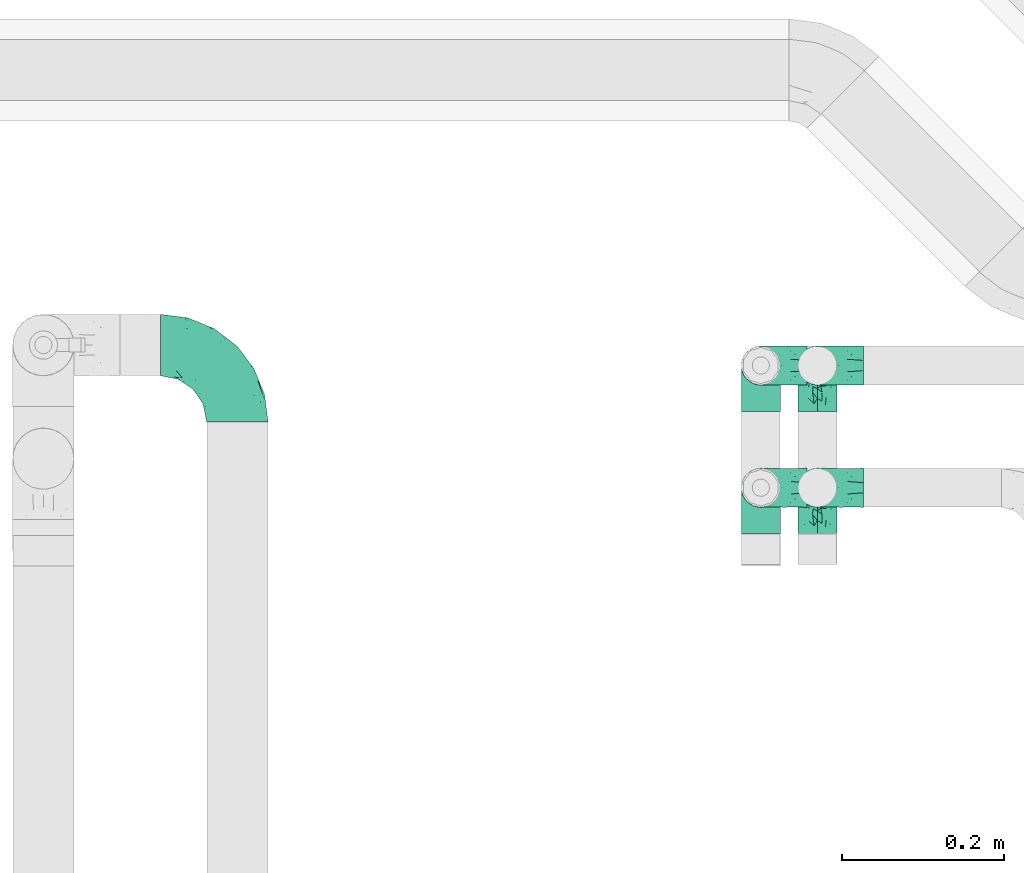
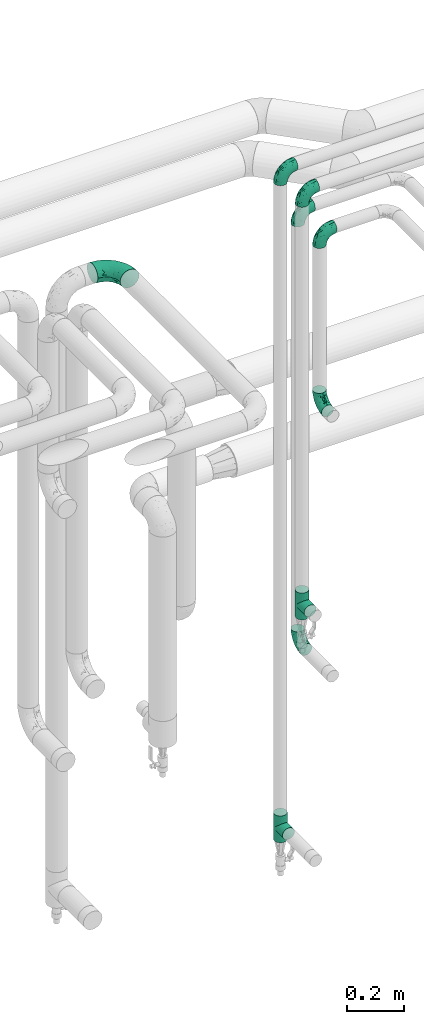
# One storey, part 678 of 827: 9 flow fittings.
"""IFC2X3 building model written with IfcOpenShell, lengths in millimetres."""

from ifc_helpers import new_model, entity, si_unit, converted_unit, derived_unit, direction, frame, origin, place, context, subcontext, project, spatial, faceted_brep, source, transform, mapped, material, type_object, type_shapes, element, save


model = new_model("IFC2X3")

# Units and contexts
model_context = context("Model", 3, precision=0.01, world=origin(), true_north=direction((6.12303176911189e-17, 1.0)))
body_context = subcontext(model_context, "Body", "Model", "MODEL_VIEW")
ifc_project = project(units=[si_unit("LENGTHUNIT", "METRE", prefix="MILLI"), si_unit("AREAUNIT", "SQUARE_METRE"), si_unit("VOLUMEUNIT", "CUBIC_METRE"), converted_unit("PLANEANGLEUNIT", "DEGREE", entity("IfcRatioMeasure", 0.0174532925199433), si_unit("PLANEANGLEUNIT", "RADIAN"), dimensions=[0, 0, 0, 0, 0, 0, 0]), si_unit("MASSUNIT", "GRAM", prefix="KILO"), derived_unit("MASSDENSITYUNIT", [(si_unit("MASSUNIT", "GRAM", prefix="KILO"), 1), (si_unit("LENGTHUNIT", "METRE"), -3)]), derived_unit("MOMENTOFINERTIAUNIT", [(si_unit("LENGTHUNIT", "METRE"), 4)]), si_unit("TIMEUNIT", "SECOND"), si_unit("FREQUENCYUNIT", "HERTZ"), si_unit("THERMODYNAMICTEMPERATUREUNIT", "DEGREE_CELSIUS"), derived_unit("THERMALTRANSMITTANCEUNIT", [(si_unit("MASSUNIT", "GRAM", prefix="KILO"), 1), (si_unit("THERMODYNAMICTEMPERATUREUNIT", "KELVIN"), -1), (si_unit("TIMEUNIT", "SECOND"), -3)]), derived_unit("VOLUMETRICFLOWRATEUNIT", [(si_unit("LENGTHUNIT", "METRE"), 3), (si_unit("TIMEUNIT", "SECOND"), -1)]), derived_unit("MASSFLOWRATEUNIT", [(si_unit("MASSUNIT", "GRAM", prefix="KILO"), 1), (si_unit("TIMEUNIT", "SECOND"), -1)]), derived_unit("ROTATIONALFREQUENCYUNIT", [(si_unit("TIMEUNIT", "SECOND"), -1)]), si_unit("ELECTRICCURRENTUNIT", "AMPERE"), si_unit("ELECTRICVOLTAGEUNIT", "VOLT"), si_unit("POWERUNIT", "WATT"), si_unit("FORCEUNIT", "NEWTON", prefix="KILO"), si_unit("ILLUMINANCEUNIT", "LUX"), si_unit("LUMINOUSFLUXUNIT", "LUMEN"), si_unit("LUMINOUSINTENSITYUNIT", "CANDELA"), derived_unit("USERDEFINED", [(si_unit("MASSUNIT", "GRAM", prefix="KILO"), -1), (si_unit("LENGTHUNIT", "METRE"), -2), (si_unit("TIMEUNIT", "SECOND"), 3), (si_unit("LUMINOUSFLUXUNIT", "LUMEN"), 1)]), derived_unit("LINEARVELOCITYUNIT", [(si_unit("LENGTHUNIT", "METRE"), 1), (si_unit("TIMEUNIT", "SECOND"), -1)]), si_unit("PRESSUREUNIT", "PASCAL"), derived_unit("USERDEFINED", [(si_unit("LENGTHUNIT", "METRE"), -2), (si_unit("MASSUNIT", "GRAM", prefix="KILO"), 1), (si_unit("TIMEUNIT", "SECOND"), -2)]), derived_unit("LINEARFORCEUNIT", [(si_unit("MASSUNIT", "GRAM", prefix="KILO"), 1), (si_unit("LENGTHUNIT", "METRE"), 1), (si_unit("TIMEUNIT", "SECOND"), -2), (si_unit("LENGTHUNIT", "METRE"), -1)]), derived_unit("PLANARFORCEUNIT", [(si_unit("MASSUNIT", "GRAM", prefix="KILO"), 1), (si_unit("LENGTHUNIT", "METRE"), 1), (si_unit("TIMEUNIT", "SECOND"), -2), (si_unit("LENGTHUNIT", "METRE"), -2)])], contexts=[model_context])

# Site, building, storey
site_placement = place(None, origin())
site = spatial("IfcSite", under=ifc_project, at=site_placement, CompositionType="ELEMENT")
building_placement = place(site_placement, origin())
building = spatial("IfcBuilding", under=site, at=building_placement, CompositionType="ELEMENT")
storey_placement = place(building_placement, frame((0.0, 0.0, 28200.0)))
storey = spatial("IfcBuildingStorey", under=building, at=storey_placement, Name="08", CompositionType="ELEMENT", Elevation=28200.0)

# Flow fittings
ifc_material = material()
pipe_fitting_type_1 = type_object("IfcPipeFittingType", Name="ADSK_1", PredefinedType="NOTDEFINED", material=ifc_material)
shared_shape_1 = source(origin(), body_context, "Body", "Brep", [
    faceted_brep([(-57.0, 12.07, -20.91), (-57.0, 6.25, -23.33), (-57.0, 0.0, -24.15), (-57.0, -6.25, -23.33), (-57.0, -12.08, -20.91), (-57.0, -17.08, -17.08), (-57.0, -20.91, -12.08), (-57.0, -23.33, -6.25), (-57.0, -24.15, 0.0), (-57.0, -23.33, 6.25), (-57.0, -20.91, 12.07), (-57.0, -17.08, 17.08), (-57.0, -12.08, 20.91), (-57.0, -6.25, 23.33), (-57.0, 0.0, 24.15), (-57.0, 6.25, 23.33), (-57.0, 12.07, 20.91), (-57.0, 17.08, 17.08), (-57.0, 20.91, 12.07), (-57.0, 23.33, 6.25), (-57.0, 24.15, 0.0), (-57.0, 23.33, -6.25), (-57.0, 20.91, -12.08), (-57.0, 17.08, -17.08), (0.0, 57.0, -24.15), (-6.25, 57.0, -23.33), (-12.07, 57.0, -20.91), (-17.08, 57.0, -17.08), (-20.91, 57.0, -12.08), (-23.33, 57.0, -6.25), (-24.15, 57.0, 0.0), (-23.33, 57.0, 6.25), (-20.91, 57.0, 12.07), (-17.08, 57.0, 17.08), (-12.07, 57.0, 20.91), (-6.25, 57.0, 23.33), (0.0, 57.0, 24.15), (6.25, 57.0, 23.33), (12.08, 57.0, 20.91), (17.08, 57.0, 17.08), (20.91, 57.0, 12.07), (23.33, 57.0, 6.25), (24.15, 57.0, 0.0), (23.33, 57.0, -6.25), (20.91, 57.0, -12.08), (17.08, 57.0, -17.08), (12.08, 57.0, -20.91), (6.25, 57.0, -23.33), (14.9, 21.14, 6.17), (13.61, 24.64, 12.48), (6.23, 8.95, 8.98), (-41.47, -21.06, 0.0), (-41.92, -18.38, 13.72), (-24.64, -13.61, 12.48), (-37.37, -13.24, 18.15), (-6.8, -4.93, 8.18), (-21.76, -15.19, 6.22), (-12.78, -9.18, 0.0), (-37.73, -20.51, 7.75), (-7.38, 7.38, 20.24), (-23.37, -4.26, 20.42), (-11.9, -3.19, 15.86), (-42.14, -8.7, 21.82), (13.24, 37.37, 18.15), (9.33, 23.53, 16.85), (4.26, 23.37, 20.42), (2.77, 10.92, 15.55), (-29.46, 0.91, 23.52), (-44.13, 20.56, 15.69), (-39.25, 26.33, 10.88), (-49.02, 22.92, 9.96), (-34.58, 23.87, 17.15), (-15.8, 6.8, 22.81), (-8.67, 20.47, 23.88), (-18.12, 12.9, 24.08), (-48.29, 14.92, 19.65), (-44.06, -2.85, 23.78), (-9.23, 48.95, 22.58), (-3.78, 42.74, 24.07), (-40.34, 4.26, 24.09), (-44.02, 26.14, 5.46), (-44.04, 9.88, 22.74), (-4.95, 16.87, 22.52), (-2.75, 1.43, 12.5), (-25.48, 40.98, 10.71), (20.51, 37.73, 7.75), (18.38, 41.92, 13.72), (8.7, 42.14, 21.82), (-25.95, -17.97, 0.0), (2.85, 44.06, 23.78), (21.06, 41.47, 0.0), (17.97, 25.95, 0.0), (-24.04, -9.27, 17.13), (-33.26, 33.26, 5.86), (-28.55, 40.57, 0.0), (-40.57, 28.55, 0.0), (-25.29, 47.19, 4.06), (-27.01, 31.1, 16.77), (-15.7, 43.95, 19.9), (-20.27, 45.22, 15.61), (-30.53, 31.98, 12.64), (-11.28, 38.33, 22.92), (-9.97, 27.88, 24.09), (-20.15, 30.26, 21.25), (-31.25, 11.75, 23.64), (-28.75, 7.23, 24.15), (-29.53, 18.06, 22.27), (-28.44, 24.21, 20.02), (-37.55, 17.7, 20.26), (-15.88, 29.25, 22.99), (-20.82, 20.82, 23.44), (-0.91, 29.46, 23.52), (-13.5, -7.67, 12.04), (1.49, 1.56, 5.16), (8.86, 10.35, 4.59), (0.38, -0.38, 0.0), (9.18, 12.78, 0.0), (-37.37, -13.24, -18.15), (8.86, 10.35, -4.59), (-45.22, 20.27, -15.61), (-43.95, 15.7, -19.9), (-38.33, 11.28, -22.92), (-48.95, 9.23, -22.58), (-47.19, 25.29, -4.06), (-33.26, 33.26, -5.86), (18.38, 41.92, -13.72), (-30.26, 20.15, -21.25), (2.85, 44.06, -23.78), (-4.26, 40.34, -24.09), (-40.98, 25.48, -10.71), (-41.92, -18.38, -13.72), (9.25, 23.5, -16.92), (4.26, 23.37, -20.42), (13.24, 37.37, -18.15), (-37.73, -20.51, -7.75), (-11.75, 31.25, -23.64), (-7.23, 28.75, -24.15), (-12.9, 18.12, -24.08), (8.7, 42.14, -21.82), (-44.06, -2.85, -23.78), (-6.8, 15.8, -22.81), (-20.47, 8.67, -23.88), (-24.64, -13.61, -12.48), (-42.74, 3.78, -24.07), (-18.06, 29.53, -22.27), (-24.21, 28.44, -20.02), (-27.88, 9.97, -24.09), (-31.1, 27.01, -16.77), (-26.14, 44.02, -5.46), (14.9, 21.14, -6.17), (20.51, 37.73, -7.75), (-9.88, 44.04, -22.74), (-20.56, 44.13, -15.69), (-21.76, -15.19, -6.22), (-13.5, -7.67, -12.04), (-24.14, -9.76, -16.74), (-11.9, -3.19, -15.86), (-14.92, 48.29, -19.65), (-23.37, -4.26, -20.42), (-0.91, 29.46, -23.52), (-26.33, 39.25, -10.88), (-23.87, 34.58, -17.15), (-42.14, -8.7, -21.82), (-22.92, 49.02, -9.96), (13.61, 24.64, -12.48), (-31.98, 30.53, -12.64), (-16.87, 4.95, -22.52), (-17.7, 37.55, -20.26), (-29.25, 15.88, -22.99), (-20.82, 20.82, -23.44), (-29.46, 0.91, -23.52), (-7.38, 7.38, -20.24), (2.77, 10.92, -15.55), (6.23, 8.95, -8.98), (-6.8, -4.93, -8.18), (-2.81, 1.41, -12.54), (1.49, 1.56, -5.16)], [[[0, 1, 2, 3, 4, 5, 6, 7, 8, 9, 10, 11, 12, 13, 14, 15, 16, 17, 18, 19, 20, 21, 22, 23]], [[24, 25, 26, 27, 28, 29, 30, 31, 32, 33, 34, 35, 36, 37, 38, 39, 40, 41, 42, 43, 44, 45, 46, 47]], [[48, 49, 50]], [[9, 8, 51]], [[52, 53, 54]], [[55, 56, 57]], [[10, 58, 52]], [[9, 58, 10]], [[59, 60, 61]], [[54, 12, 11]], [[54, 62, 12]], [[63, 39, 38]], [[64, 65, 66]], [[62, 60, 67]], [[68, 69, 70]], [[71, 69, 68]], [[72, 73, 74]], [[16, 75, 17]], [[13, 76, 14]], [[35, 77, 78]], [[14, 79, 15]], [[17, 68, 18]], [[14, 76, 79]], [[20, 19, 80]], [[70, 19, 18]], [[81, 15, 79]], [[15, 81, 16]], [[73, 72, 82]], [[66, 83, 50]], [[32, 31, 84]], [[85, 86, 49]], [[63, 87, 65]], [[56, 58, 88]], [[36, 89, 37]], [[85, 41, 40]], [[36, 35, 78]], [[90, 41, 85]], [[40, 39, 86]], [[12, 62, 13]], [[86, 85, 40]], [[48, 85, 49]], [[85, 91, 90]], [[87, 38, 37]], [[92, 60, 54]], [[80, 69, 93]], [[93, 94, 95]], [[10, 52, 11]], [[94, 96, 30]], [[97, 98, 99]], [[80, 93, 95]], [[100, 97, 84]], [[99, 98, 33]], [[101, 102, 78]], [[103, 101, 98]], [[96, 31, 30]], [[77, 98, 101]], [[77, 35, 34]], [[34, 33, 98]], [[9, 51, 58]], [[87, 63, 38]], [[104, 105, 74]], [[106, 103, 107]], [[106, 81, 104]], [[75, 68, 17]], [[108, 107, 71]], [[33, 32, 99]], [[109, 103, 110]], [[101, 109, 102]], [[89, 78, 111]], [[53, 52, 58]], [[54, 11, 52]], [[60, 62, 54]], [[88, 58, 51]], [[76, 62, 67]], [[53, 112, 92]], [[60, 59, 72]], [[39, 63, 86]], [[49, 86, 63]], [[89, 87, 37]], [[42, 41, 90]], [[111, 82, 65]], [[111, 65, 87]], [[65, 59, 66]], [[104, 81, 79]], [[75, 81, 108]], [[32, 84, 99]], [[97, 99, 84]], [[98, 97, 103]], [[106, 107, 108]], [[74, 102, 110]], [[111, 78, 102]], [[74, 110, 104]], [[74, 67, 72]], [[61, 92, 112]], [[66, 59, 61]], [[56, 53, 58]], [[66, 50, 49]], [[61, 112, 83]], [[66, 49, 64]], [[78, 89, 36]], [[87, 89, 111]], [[62, 76, 13]], [[79, 76, 67]], [[100, 93, 69]], [[96, 93, 84]], [[55, 113, 50]], [[113, 114, 50]], [[104, 79, 105]], [[106, 104, 110]], [[20, 80, 95]], [[85, 48, 91]], [[115, 114, 113]], [[116, 91, 48]], [[70, 80, 19]], [[93, 96, 94]], [[84, 31, 96]], [[103, 106, 110]], [[81, 106, 108]], [[103, 97, 107]], [[71, 107, 97]], [[71, 97, 100]], [[108, 71, 68]], [[79, 67, 105]], [[67, 74, 105]], [[115, 113, 57]], [[112, 56, 55]], [[56, 88, 57]], [[60, 72, 67]], [[82, 72, 59]], [[65, 82, 59]], [[82, 111, 73]], [[111, 102, 73]], [[102, 74, 73]], [[81, 75, 16]], [[68, 75, 108]], [[68, 70, 18]], [[80, 70, 69]], [[98, 77, 34]], [[78, 77, 101]], [[93, 100, 84]], [[71, 100, 69]], [[102, 109, 110]], [[101, 103, 109]], [[53, 92, 54]], [[61, 60, 92]], [[56, 112, 53]], [[83, 112, 55]], [[50, 83, 55]], [[61, 83, 66]], [[49, 63, 64]], [[65, 64, 63]], [[57, 113, 55]], [[114, 115, 116]], [[116, 48, 114]], [[48, 50, 114]], [[117, 5, 4]], [[116, 115, 118]], [[119, 120, 23]], [[121, 122, 120]], [[95, 123, 20]], [[0, 23, 120]], [[124, 95, 94]], [[125, 45, 44]], [[121, 120, 126]], [[24, 127, 128]], [[22, 21, 129]], [[0, 122, 1]], [[5, 117, 130]], [[131, 132, 133]], [[134, 88, 51]], [[135, 136, 137]], [[6, 5, 130]], [[46, 138, 47]], [[139, 3, 2]], [[140, 141, 137]], [[6, 134, 7]], [[134, 130, 142]], [[143, 2, 1]], [[144, 126, 145]], [[121, 146, 143]], [[147, 120, 119]], [[94, 148, 124]], [[149, 150, 91]], [[30, 29, 148]], [[151, 25, 128]], [[27, 152, 28]], [[134, 153, 88]], [[154, 155, 156]], [[27, 26, 157]], [[151, 26, 25]], [[155, 158, 156]], [[24, 47, 127]], [[1, 122, 143]], [[138, 132, 159]], [[160, 152, 161]], [[24, 128, 25]], [[46, 133, 138]], [[162, 117, 4]], [[148, 160, 124]], [[152, 160, 163]], [[154, 142, 155]], [[45, 125, 133]], [[133, 46, 45]], [[125, 164, 133]], [[51, 7, 134]], [[42, 90, 43]], [[165, 147, 129]], [[153, 134, 142]], [[43, 150, 44]], [[162, 4, 3]], [[141, 140, 166]], [[117, 162, 158]], [[163, 29, 28]], [[43, 90, 150]], [[123, 21, 20]], [[144, 151, 135]], [[157, 152, 27]], [[167, 145, 161]], [[23, 22, 119]], [[168, 126, 169]], [[121, 168, 146]], [[139, 143, 170]], [[142, 130, 117]], [[8, 7, 51]], [[134, 6, 130]], [[139, 162, 3]], [[170, 166, 158]], [[170, 158, 162]], [[158, 171, 156]], [[44, 150, 125]], [[91, 150, 90]], [[164, 125, 150]], [[132, 138, 133]], [[127, 138, 159]], [[131, 164, 172]], [[132, 171, 140]], [[135, 151, 128]], [[157, 151, 167]], [[22, 129, 119]], [[147, 119, 129]], [[120, 147, 126]], [[144, 145, 167]], [[137, 146, 169]], [[170, 143, 146]], [[137, 169, 135]], [[137, 159, 140]], [[171, 172, 156]], [[173, 174, 175]], [[156, 175, 154]], [[174, 57, 153]], [[132, 172, 171]], [[172, 164, 173]], [[143, 139, 2]], [[162, 139, 170]], [[138, 127, 47]], [[128, 127, 159]], [[165, 124, 160]], [[123, 124, 129]], [[149, 173, 164]], [[176, 174, 173]], [[135, 128, 136]], [[144, 135, 169]], [[150, 149, 164]], [[176, 118, 115]], [[149, 91, 116]], [[30, 148, 94]], [[163, 148, 29]], [[124, 123, 95]], [[129, 21, 123]], [[126, 144, 169]], [[151, 144, 167]], [[126, 147, 145]], [[161, 145, 147]], [[161, 147, 165]], [[167, 161, 152]], [[128, 159, 136]], [[159, 137, 136]], [[154, 153, 142]], [[132, 140, 159]], [[174, 176, 57]], [[57, 88, 153]], [[166, 140, 171]], [[158, 166, 171]], [[166, 170, 141]], [[170, 146, 141]], [[146, 137, 141]], [[151, 157, 26]], [[152, 157, 167]], [[152, 163, 28]], [[148, 163, 160]], [[120, 122, 0]], [[143, 122, 121]], [[124, 165, 129]], [[161, 165, 160]], [[146, 168, 169]], [[121, 126, 168]], [[142, 117, 155]], [[158, 155, 117]], [[175, 156, 172]], [[153, 154, 174]], [[173, 175, 172]], [[174, 154, 175]], [[164, 131, 133]], [[172, 132, 131]], [[176, 173, 118]], [[57, 176, 115]], [[173, 149, 118]], [[149, 116, 118]]]),
])
type_shapes(pipe_fitting_type_1, [shared_shape_1])
for number, where, z_axis, x_axis, name in (
    (1, (47639.84, 18240.89, 3200.0), (0.0, -1.0, 0.0), (-1.0, 0.0, 0.0), "ADSK_1"),
    (2, (47639.84, 18089.64, 3200.0), (0.0, -1.0, 0.0), (-1.0, 0.0, 0.0), "ADSK_1"),
    (3, (47709.84, 18240.89, 3000.0), (0.0, -1.0, 0.0), (-1.0, 0.0, 0.0), "ADSK_1"),
    (4, (47709.84, 18240.89, 1160.0), (-1.0, 0.0, 0.0), (0.0, 0.0, -1.0), "ADSK_1"),
    (5, (47709.84, 18089.64, 3000.0), (0.0, -1.0, 0.0), (-1.0, 0.0, 0.0), "ADSK_1"),
    (6, (47709.84, 18089.64, 2268.61), (-1.0, 0.0, 0.0), (0.0, 0.0, -1.0), "ADSK_1"),
):
    element("IfcFlowFitting", number, at=place(storey_placement, frame(where, z_axis=z_axis, x_axis=x_axis)), inside=storey, type_object=pipe_fitting_type_1, material=ifc_material, Name=name, ObjectType="ADSK_1", context=body_context, shape_type="MappedRepresentation", body=[
        mapped(shared_shape_1, transform((0.0, 0.0, 0.0), scale=1.0)),
    ])
pipe_fitting_type_2 = type_object("IfcPipeFittingType", Name="ADSK_1", PredefinedType="NOTDEFINED", material=ifc_material)
shared_shape_2 = source(origin(), body_context, "Body", "Brep", [
    faceted_brep([(-57.0, 12.07, -20.91), (-57.0, 6.25, -23.33), (-57.0, 0.0, -24.15), (-57.0, -6.25, -23.33), (-57.0, -12.08, -20.91), (-57.0, -17.08, -17.08), (-57.0, -20.91, -12.08), (-57.0, -23.33, -6.25), (-57.0, -24.15, 0.0), (-57.0, -23.33, 6.25), (-57.0, -20.91, 12.07), (-57.0, -17.08, 17.08), (-57.0, -12.08, 20.91), (-57.0, -6.25, 23.33), (-57.0, 0.0, 24.15), (-57.0, 6.25, 23.33), (-57.0, 12.07, 20.91), (-57.0, 17.08, 17.08), (-57.0, 20.91, 12.07), (-57.0, 23.33, 6.25), (-57.0, 24.15, 0.0), (-57.0, 23.33, -6.25), (-57.0, 20.91, -12.08), (-57.0, 17.08, -17.08), (57.0, 0.0, -24.15), (57.0, 6.25, -23.33), (57.0, 12.07, -20.91), (57.0, 17.08, -17.08), (57.0, 20.91, -12.08), (57.0, 23.33, -6.25), (57.0, 24.15, 0.0), (57.0, 23.33, 6.25), (57.0, 20.91, 12.07), (57.0, 17.08, 17.08), (57.0, 12.07, 20.91), (57.0, 6.25, 23.33), (57.0, 0.0, 24.15), (57.0, -6.25, 23.33), (57.0, -12.08, 20.91), (57.0, -17.08, 17.08), (57.0, -20.91, 12.07), (57.0, -23.33, 6.25), (57.0, -24.15, 0.0), (57.0, -23.33, -6.25), (57.0, -20.91, -12.08), (57.0, -17.08, -17.08), (57.0, -12.08, -20.91), (57.0, -6.25, -23.33), (23.27, -23.27, 6.45), (24.15, -24.15, 0.0), (-24.15, -24.15, 0.0), (20.9, -20.9, 12.1), (13.54, -13.54, 20.0), (17.52, -17.52, 16.62), (-23.27, -23.27, 6.45), (-20.9, -20.9, 12.1), (-17.52, -17.52, 16.62), (-13.54, -13.54, 20.0), (-9.19, -9.19, 22.33), (9.19, -9.19, 22.33), (4.64, -4.64, 23.7), (0.0, 0.0, 24.15), (-4.64, -4.64, 23.7), (4.64, -4.64, -23.7), (0.0, 0.0, -24.15), (-4.64, -4.64, -23.7), (-9.19, -9.19, -22.33), (9.19, -9.19, -22.33), (13.54, -13.54, -20.0), (17.52, -17.52, -16.62), (20.9, -20.9, -12.1), (23.27, -23.27, -6.45), (-13.54, -13.54, -20.0), (-17.52, -17.52, -16.62), (-23.27, -23.27, -6.45), (-20.9, -20.9, -12.1), (0.0, -57.0, -24.15), (6.25, -57.0, -23.33), (12.08, -57.0, -20.91), (17.08, -57.0, -17.08), (20.91, -57.0, -12.08), (23.33, -57.0, -6.25), (24.15, -57.0, 0.0), (23.33, -57.0, 6.25), (20.91, -57.0, 12.07), (17.08, -57.0, 17.08), (12.08, -57.0, 20.91), (6.25, -57.0, 23.33), (0.0, -57.0, 24.15), (-6.25, -57.0, 23.33), (-12.07, -57.0, 20.91), (-17.08, -57.0, 17.08), (-20.91, -57.0, 12.07), (-23.33, -57.0, 6.25), (-24.15, -57.0, 0.0), (-23.33, -57.0, -6.25), (-20.91, -57.0, -12.08), (-17.08, -57.0, -17.08), (-12.07, -57.0, -20.91), (-6.25, -57.0, -23.33)], [[[0, 1, 2, 3, 4, 5, 6, 7, 8, 9, 10, 11, 12, 13, 14, 15, 16, 17, 18, 19, 20, 21, 22, 23]], [[24, 25, 26, 27, 28, 29, 30, 31, 32, 33, 34, 35, 36, 37, 38, 39, 40, 41, 42, 43, 44, 45, 46, 47]], [[41, 40, 48]], [[42, 41, 49]], [[50, 9, 8]], [[49, 41, 48]], [[40, 51, 48]], [[39, 38, 52]], [[51, 40, 53]], [[52, 53, 39]], [[53, 40, 39]], [[50, 54, 9]], [[9, 54, 10]], [[54, 55, 10]], [[56, 57, 11]], [[11, 10, 56]], [[11, 57, 12]], [[56, 10, 55]], [[12, 57, 58]], [[52, 38, 59]], [[60, 36, 61]], [[62, 61, 14]], [[59, 37, 60]], [[37, 59, 38]], [[60, 37, 36]], [[61, 36, 35, 15, 14]], [[32, 31, 19, 18]], [[17, 16, 34, 33]], [[18, 17, 33, 32]], [[35, 34, 16, 15]], [[20, 19, 31, 30]], [[62, 13, 58]], [[13, 62, 14]], [[58, 13, 12]], [[27, 23, 22, 28]], [[22, 21, 29, 28]], [[0, 23, 27, 26]], [[20, 30, 29, 21]], [[24, 47, 63]], [[24, 64, 2, 1, 25]], [[64, 24, 63]], [[2, 64, 65]], [[26, 25, 1, 0]], [[65, 66, 3]], [[2, 65, 3]], [[66, 4, 3]], [[63, 47, 67]], [[46, 45, 68]], [[69, 68, 45]], [[44, 70, 69]], [[69, 45, 44]], [[46, 68, 67]], [[43, 42, 49]], [[7, 50, 8]], [[43, 71, 44]], [[71, 43, 49]], [[44, 71, 70]], [[72, 4, 66]], [[72, 5, 4]], [[5, 72, 73]], [[5, 73, 6]], [[74, 50, 7]], [[75, 74, 6]], [[74, 7, 6]], [[75, 6, 73]], [[46, 67, 47]], [[76, 77, 78, 79, 80, 81, 82, 83, 84, 85, 86, 87, 88, 89, 90, 91, 92, 93, 94, 95, 96, 97, 98, 99]], [[50, 94, 93]], [[54, 50, 93]], [[91, 90, 57]], [[56, 92, 91]], [[54, 93, 92]], [[58, 90, 89]], [[55, 54, 92]], [[56, 55, 92]], [[58, 57, 90]], [[88, 61, 62]], [[58, 89, 62]], [[56, 91, 57]], [[62, 89, 88]], [[60, 88, 87]], [[86, 59, 87]], [[84, 83, 48]], [[53, 85, 84]], [[52, 86, 85]], [[49, 83, 82]], [[59, 60, 87]], [[52, 59, 86]], [[49, 48, 83]], [[51, 53, 84]], [[48, 51, 84]], [[52, 85, 53]], [[88, 60, 61]], [[82, 81, 49]], [[71, 49, 81]], [[69, 80, 79]], [[79, 78, 68]], [[71, 81, 80]], [[67, 78, 77]], [[70, 71, 80]], [[69, 70, 80]], [[67, 68, 78]], [[76, 64, 63]], [[67, 77, 63]], [[69, 79, 68]], [[63, 77, 76]], [[65, 76, 99]], [[98, 66, 99]], [[96, 95, 74]], [[73, 97, 96]], [[72, 98, 97]], [[50, 95, 94]], [[66, 65, 99]], [[72, 66, 98]], [[50, 74, 95]], [[75, 73, 96]], [[74, 75, 96]], [[72, 97, 73]], [[76, 65, 64]]]),
])
type_shapes(pipe_fitting_type_2, [shared_shape_2])
for number, where, z_axis, x_axis, name in (
    (7, (47639.84, 18240.89, 400.0), (1.0, 0.0, 0.0), (0.0, 0.0, -1.0), "ADSK_1"),
    (8, (47639.84, 18089.64, 1441.5), (1.0, 0.0, 0.0), (0.0, 0.0, -1.0), "ADSK_1"),
):
    element("IfcFlowFitting", number, at=place(storey_placement, frame(where, z_axis=z_axis, x_axis=x_axis)), inside=storey, type_object=pipe_fitting_type_2, material=ifc_material, Name=name, ObjectType="ADSK_1", context=body_context, shape_type="MappedRepresentation", body=[
        mapped(shared_shape_2, transform((0.0, 0.0, 0.0), scale=1.0)),
    ])
pipe_fitting_type_3 = type_object("IfcPipeFittingType", Name="ADSK_1", PredefinedType="NOTDEFINED", material=ifc_material)
shared_shape_3 = source(origin(), body_context, "Body", "Brep", [
    faceted_brep([(-95.0, 19.02, -32.95), (-95.0, 9.85, -36.75), (-95.0, 0.0, -38.05), (-95.0, -9.85, -36.75), (-95.0, -19.03, -32.95), (-95.0, -26.91, -26.91), (-95.0, -32.95, -19.03), (-95.0, -36.75, -9.85), (-95.0, -38.05, 0.0), (-95.0, -36.75, 9.85), (-95.0, -32.95, 19.02), (-95.0, -26.91, 26.91), (-95.0, -19.03, 32.95), (-95.0, -9.85, 36.75), (-95.0, 0.0, 38.05), (-95.0, 9.85, 36.75), (-95.0, 19.02, 32.95), (-95.0, 26.91, 26.91), (-95.0, 32.95, 19.02), (-95.0, 36.75, 9.85), (-95.0, 38.05, 0.0), (-95.0, 36.75, -9.85), (-95.0, 32.95, -19.03), (-95.0, 26.91, -26.91), (0.0, 95.0, -38.05), (-9.85, 95.0, -36.75), (-19.02, 95.0, -32.95), (-26.91, 95.0, -26.91), (-32.95, 95.0, -19.03), (-36.75, 95.0, -9.85), (-38.05, 95.0, 0.0), (-36.75, 95.0, 9.85), (-32.95, 95.0, 19.02), (-26.91, 95.0, 26.91), (-19.02, 95.0, 32.95), (-9.85, 95.0, 36.75), (0.0, 95.0, 38.05), (9.85, 95.0, 36.75), (19.03, 95.0, 32.95), (26.91, 95.0, 26.91), (32.95, 95.0, 19.02), (36.75, 95.0, 9.85), (38.05, 95.0, 0.0), (36.75, 95.0, -9.85), (32.95, 95.0, -19.03), (26.91, 95.0, -26.91), (19.03, 95.0, -32.95), (9.85, 95.0, -36.75), (-7.99, -4.96, 6.3), (-0.92, 0.92, 0.0), (4.62, 8.1, 8.01), (-76.19, -35.57, 0.0), (-64.32, -32.32, 12.43), (20.51, 62.45, 28.68), (-60.56, -33.52, 0.0), (-70.4, -13.47, 34.42), (-39.61, -5.88, 32.32), (-49.6, 2.07, 37.1), (-70.34, -28.81, 21.71), (14.64, 40.81, 26.5), (5.88, 39.61, 32.32), (3.59, 20.77, 25.31), (-40.45, 68.06, 16.75), (-62.45, -20.51, 28.68), (-44.52, -26.87, 0.0), (-28.47, -20.22, 0.0), (-26.43, -17.83, 8.75), (-76.1, 39.63, 10.76), (-72.74, 37.58, 18.19), (-60.35, 46.18, 14.61), (-13.4, 13.4, 32.12), (-20.77, -3.59, 25.31), (-14.66, 81.47, 35.56), (-6.22, 71.26, 37.92), (-57.5, 42.48, 22.79), (-15.0, 34.74, 37.7), (-27.1, 12.08, 36.05), (-9.2, 28.81, 35.63), (-79.98, 23.7, 30.95), (-73.68, -4.3, 37.48), (-30.74, 21.67, 37.97), (-62.36, 47.59, 6.79), (-72.71, 32.83, 24.69), (-67.42, 7.02, 37.95), (-32.13, 75.27, 24.51), (-43.46, 51.47, 26.26), (-24.98, 73.15, 31.29), (20.59, 41.28, 19.85), (7.79, 16.09, 15.86), (-73.21, 42.39, 0.0), (-54.73, 54.73, 0.0), (-73.44, 15.79, 35.79), (-5.94, 4.32, 20.43), (28.81, 70.34, 21.71), (32.32, 64.32, 12.43), (-53.59, 26.2, 35.09), (-52.02, 19.31, 37.21), (21.38, 33.53, 10.34), (26.87, 44.52, 0.0), (-48.28, 12.14, 38.05), (4.3, 73.68, 37.48), (-44.08, -25.52, 12.79), (-41.28, -20.59, 19.85), (35.57, 76.19, 0.0), (-47.26, 54.3, 20.18), (-47.4, 61.99, 8.58), (-42.39, 73.21, 0.0), (-39.67, 78.86, 7.21), (-45.69, 36.84, 33.11), (-32.83, 50.13, 33.35), (13.47, 70.4, 34.42), (-18.25, 63.73, 36.07), (-40.63, -13.75, 27.22), (-16.63, 46.37, 37.95), (-53.47, 38.79, 28.59), (-26.07, 48.54, 36.15), (-34.51, 34.51, 36.86), (-2.07, 49.6, 37.1), (-22.79, -10.49, 19.23), (-61.73, 28.67, 31.87), (9.65, 14.7, 0.0), (20.22, 28.47, 0.0), (33.52, 60.56, 0.0), (-11.42, -5.44, 13.25), (-14.7, -9.65, 0.0), (-81.47, 14.66, -35.56), (-62.45, -20.51, -28.68), (-71.26, 6.22, -37.92), (-75.27, 32.13, -24.51), (-73.15, 24.98, -31.29), (13.47, 70.4, -34.42), (5.88, 39.61, -32.32), (-2.07, 49.6, -37.1), (-78.86, 39.67, -7.21), (-70.4, -13.47, -34.42), (-39.61, -5.88, -32.32), (-61.99, 47.4, -8.58), (32.32, 64.32, -12.43), (28.81, 70.34, -21.71), (-63.73, 18.25, -36.07), (-50.13, 32.83, -33.35), (4.3, 73.68, -37.48), (-7.02, 67.42, -37.95), (-39.63, 76.1, -10.76), (-46.18, 60.35, -14.61), (-47.59, 62.36, -6.79), (-64.32, -32.32, -12.43), (-26.2, 53.59, -35.09), (-15.79, 73.44, -35.79), (-19.31, 52.02, -37.21), (-37.58, 72.74, -18.19), (-70.34, -28.81, -21.71), (-42.48, 57.5, -22.79), (-38.79, 53.47, -28.59), (-51.47, 43.46, -26.26), (-32.83, 72.71, -24.69), (-46.37, 16.63, -37.95), (-73.68, -4.3, -37.48), (-41.28, -20.59, -19.85), (-44.08, -25.52, -12.79), (13.75, 40.63, -27.22), (20.51, 62.45, -28.68), (-68.06, 40.45, -16.75), (-54.3, 47.26, -20.18), (-12.14, 48.28, -38.05), (-21.67, 30.74, -37.97), (-36.84, 45.69, -33.11), (-11.42, -5.44, -13.25), (7.79, 16.09, -15.86), (4.62, 8.1, -8.01), (-23.7, 79.98, -30.95), (-26.43, -17.83, -8.75), (-7.99, -4.96, -6.3), (-40.81, -14.64, -26.5), (-20.77, -3.59, -25.31), (-34.74, 15.0, -37.7), (-12.08, 27.1, -36.05), (-28.81, 9.2, -35.63), (-22.79, -10.49, -19.23), (21.38, 33.53, -10.34), (20.59, 41.28, -19.85), (-48.54, 26.07, -36.15), (-49.6, 2.07, -37.1), (-13.4, 13.4, -32.12), (3.59, 20.77, -25.31), (-28.67, 61.73, -31.87), (-34.51, 34.51, -36.86), (-5.94, 4.32, -20.43)], [[[0, 1, 2, 3, 4, 5, 6, 7, 8, 9, 10, 11, 12, 13, 14, 15, 16, 17, 18, 19, 20, 21, 22, 23]], [[24, 25, 26, 27, 28, 29, 30, 31, 32, 33, 34, 35, 36, 37, 38, 39, 40, 41, 42, 43, 44, 45, 46, 47]], [[48, 49, 50]], [[51, 52, 9]], [[53, 39, 38]], [[9, 52, 10]], [[54, 52, 51]], [[55, 56, 57]], [[11, 10, 58]], [[59, 60, 61]], [[32, 31, 62]], [[63, 12, 11]], [[63, 55, 12]], [[64, 65, 66]], [[67, 68, 69]], [[70, 56, 71]], [[35, 72, 73]], [[69, 68, 74]], [[75, 76, 77]], [[16, 78, 17]], [[13, 79, 14]], [[76, 75, 80]], [[67, 69, 81]], [[18, 17, 82]], [[14, 79, 83]], [[20, 19, 67]], [[84, 85, 86]], [[87, 61, 88]], [[89, 81, 90]], [[18, 82, 68]], [[15, 91, 16]], [[14, 83, 15]], [[71, 92, 61]], [[17, 78, 82]], [[93, 87, 94]], [[95, 91, 96]], [[97, 98, 94]], [[86, 72, 34]], [[96, 99, 80]], [[37, 36, 100]], [[40, 39, 93]], [[40, 94, 41]], [[64, 66, 101]], [[93, 94, 40]], [[58, 102, 63]], [[94, 103, 41]], [[94, 87, 97]], [[104, 69, 74]], [[34, 33, 86]], [[105, 69, 104]], [[52, 58, 10]], [[106, 107, 30]], [[108, 109, 85]], [[105, 106, 90]], [[53, 110, 60]], [[86, 111, 72]], [[86, 109, 111]], [[33, 84, 86]], [[12, 55, 13]], [[112, 56, 63]], [[110, 38, 37]], [[34, 72, 35]], [[36, 35, 73]], [[111, 113, 73]], [[105, 107, 106]], [[110, 53, 38]], [[74, 114, 85]], [[91, 15, 83]], [[105, 90, 81]], [[107, 62, 31]], [[33, 32, 84]], [[115, 109, 116]], [[111, 115, 113]], [[100, 73, 117]], [[56, 55, 63]], [[79, 55, 57]], [[102, 118, 112]], [[56, 70, 76]], [[100, 110, 37]], [[117, 77, 60]], [[117, 60, 110]], [[60, 70, 61]], [[58, 52, 101]], [[63, 11, 58]], [[39, 53, 93]], [[87, 93, 53]], [[96, 91, 83]], [[78, 91, 119]], [[32, 62, 84]], [[84, 62, 104]], [[86, 85, 109]], [[85, 114, 108]], [[80, 113, 116]], [[117, 73, 113]], [[80, 116, 96]], [[80, 57, 76]], [[71, 112, 118]], [[61, 87, 59]], [[62, 107, 105]], [[97, 120, 121]], [[70, 71, 61]], [[71, 118, 92]], [[73, 100, 36]], [[110, 100, 117]], [[55, 79, 13]], [[83, 79, 57]], [[96, 83, 99]], [[116, 108, 95]], [[50, 97, 88]], [[97, 87, 88]], [[50, 49, 120]], [[122, 94, 98]], [[89, 20, 67]], [[105, 81, 69]], [[89, 67, 81]], [[68, 19, 18]], [[68, 67, 19]], [[74, 68, 82]], [[114, 82, 119]], [[74, 85, 104]], [[82, 114, 74]], [[114, 119, 108]], [[95, 108, 119]], [[116, 109, 108]], [[123, 48, 50]], [[97, 50, 120]], [[123, 50, 88]], [[91, 95, 119]], [[116, 95, 96]], [[84, 104, 85]], [[104, 62, 105]], [[83, 57, 99]], [[57, 80, 99]], [[66, 48, 123]], [[66, 124, 48]], [[118, 66, 123]], [[124, 66, 65]], [[66, 118, 101]], [[54, 64, 52]], [[124, 49, 48]], [[30, 107, 31]], [[91, 78, 16]], [[82, 78, 119]], [[56, 76, 57]], [[77, 76, 70]], [[60, 77, 70]], [[77, 117, 75]], [[117, 113, 75]], [[113, 80, 75]], [[9, 8, 51]], [[103, 94, 122]], [[103, 42, 41]], [[73, 72, 111]], [[113, 115, 116]], [[111, 109, 115]], [[102, 112, 63]], [[71, 56, 112]], [[118, 102, 101]], [[92, 123, 88]], [[123, 92, 118]], [[61, 92, 88]], [[87, 53, 59]], [[60, 59, 53]], [[97, 121, 98]], [[58, 101, 102]], [[64, 101, 52]], [[125, 1, 0]], [[126, 5, 4]], [[2, 1, 127]], [[1, 125, 127]], [[128, 129, 23]], [[130, 131, 132]], [[89, 133, 20]], [[126, 134, 135]], [[136, 89, 90]], [[137, 138, 44]], [[139, 129, 140]], [[24, 141, 142]], [[143, 144, 145]], [[125, 129, 139]], [[6, 146, 7]], [[147, 148, 149]], [[146, 51, 7]], [[143, 150, 144]], [[146, 6, 151]], [[152, 153, 154]], [[126, 4, 134]], [[0, 23, 129]], [[28, 155, 150]], [[43, 42, 103]], [[54, 146, 64]], [[139, 156, 127]], [[157, 3, 2]], [[151, 158, 159]], [[160, 131, 161]], [[22, 21, 162]], [[136, 144, 163]], [[149, 164, 165]], [[24, 142, 25]], [[166, 140, 154]], [[154, 129, 128]], [[143, 30, 29]], [[167, 168, 169]], [[155, 28, 27]], [[26, 170, 27]], [[171, 167, 172]], [[26, 25, 148]], [[27, 170, 155]], [[173, 135, 174]], [[144, 150, 152]], [[175, 176, 177]], [[24, 47, 141]], [[45, 161, 46]], [[148, 25, 142]], [[176, 175, 165]], [[64, 159, 171]], [[138, 45, 44]], [[130, 46, 161]], [[137, 44, 43]], [[178, 159, 158]], [[137, 103, 122]], [[163, 144, 152]], [[136, 133, 89]], [[103, 137, 43]], [[6, 5, 151]], [[178, 158, 173]], [[134, 4, 3]], [[178, 173, 174]], [[137, 98, 179]], [[145, 90, 106]], [[138, 180, 161]], [[46, 130, 47]], [[136, 90, 145]], [[133, 162, 21]], [[23, 22, 128]], [[139, 140, 181]], [[139, 181, 156]], [[157, 127, 182]], [[157, 134, 3]], [[182, 177, 135]], [[182, 135, 134]], [[135, 183, 174]], [[131, 130, 161]], [[141, 130, 132]], [[160, 180, 184]], [[131, 183, 176]], [[5, 126, 151]], [[158, 151, 126]], [[180, 138, 137]], [[161, 45, 138]], [[149, 148, 142]], [[170, 148, 185]], [[22, 162, 128]], [[128, 162, 163]], [[129, 154, 140]], [[154, 153, 166]], [[165, 156, 186]], [[182, 127, 156]], [[165, 186, 149]], [[165, 132, 176]], [[131, 184, 183]], [[187, 167, 178]], [[184, 168, 187]], [[167, 169, 172]], [[184, 180, 168]], [[174, 183, 184]], [[127, 157, 2]], [[134, 157, 182]], [[130, 141, 47]], [[142, 141, 132]], [[149, 142, 164]], [[186, 166, 147]], [[180, 179, 168]], [[169, 179, 120]], [[137, 179, 180]], [[179, 121, 120]], [[106, 30, 143]], [[136, 145, 144]], [[106, 143, 145]], [[150, 29, 28]], [[150, 143, 29]], [[152, 150, 155]], [[153, 155, 185]], [[152, 154, 163]], [[155, 153, 152]], [[153, 185, 166]], [[147, 166, 185]], [[186, 140, 166]], [[169, 120, 49]], [[169, 49, 172]], [[179, 169, 168]], [[148, 147, 185]], [[186, 147, 149]], [[128, 163, 154]], [[163, 162, 136]], [[142, 132, 164]], [[132, 165, 164]], [[171, 124, 65]], [[124, 171, 172]], [[64, 146, 159]], [[171, 159, 178]], [[171, 65, 64]], [[172, 49, 124]], [[162, 133, 136]], [[20, 133, 21]], [[148, 170, 26]], [[155, 170, 185]], [[131, 176, 132]], [[177, 176, 183]], [[135, 177, 183]], [[177, 182, 175]], [[182, 156, 175]], [[156, 165, 175]], [[51, 146, 54]], [[51, 8, 7]], [[129, 125, 0]], [[127, 125, 139]], [[140, 186, 181]], [[156, 181, 186]], [[158, 126, 173]], [[135, 173, 126]], [[187, 178, 174]], [[171, 178, 167]], [[184, 187, 174]], [[167, 187, 168]], [[180, 160, 161]], [[184, 131, 160]], [[98, 137, 122]], [[98, 121, 179]], [[151, 159, 146]]]),
])
type_shapes(pipe_fitting_type_3, [shared_shape_3])
flow_fitting_placement = place(storey_placement, frame((46992.07, 18266.24, 3000.0), z_axis=(0.0, 0.0, 1.0), x_axis=(0.0, 1.0, 0.0)))
element("IfcFlowFitting", 9, at=flow_fitting_placement, inside=storey, type_object=pipe_fitting_type_3, material=ifc_material, Name="ADSK_1", ObjectType="ADSK_1", context=body_context, shape_type="MappedRepresentation", body=[
    mapped(shared_shape_3, transform((0.0, 0.0, 0.0), scale=1.0)),
])

save(model, "model.ifc")
